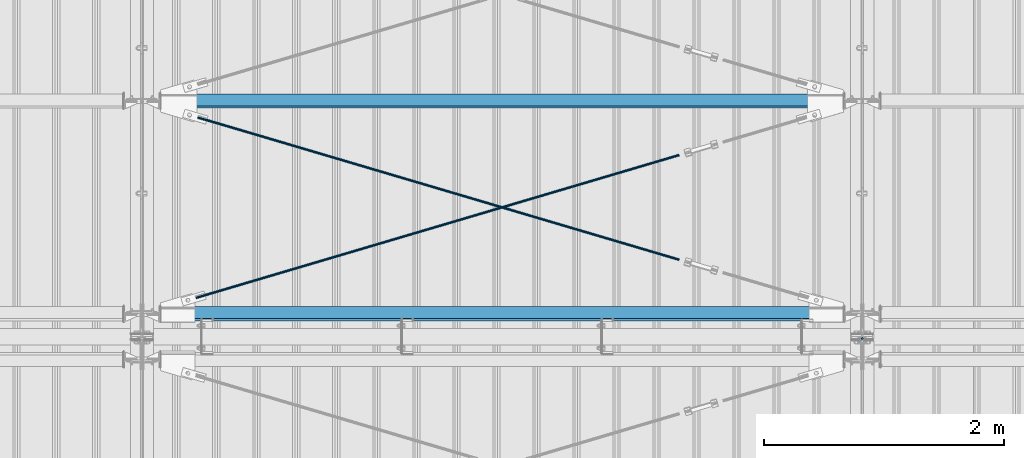
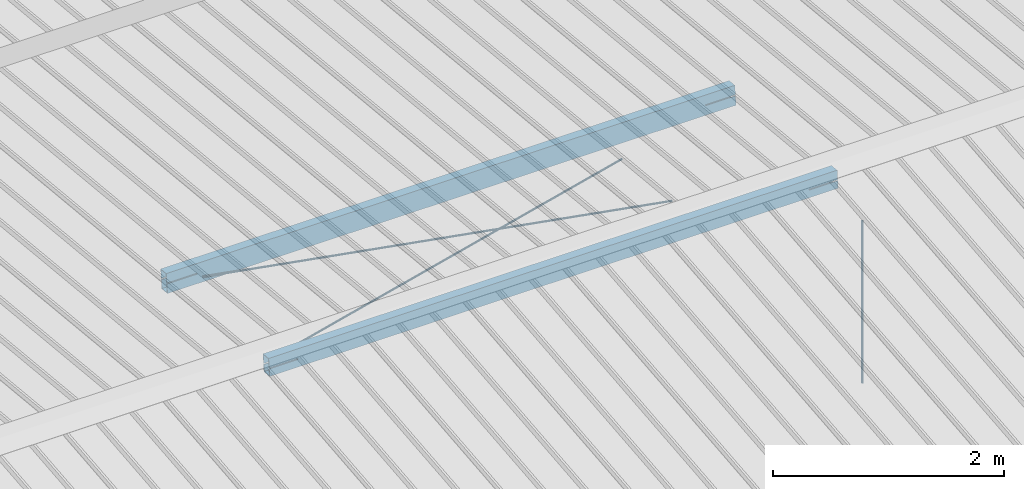
# One storey, part 281 of 709: 5 beams, 6 openings, 5 elements without a shape of their own.
"""IFC4 building model written with IfcOpenShell, lengths in millimetres."""

from ifc_helpers import new_model, si_unit, direction, frame, origin_with_axes, place, context, subcontext, project, spatial, line, indexed_curve, outline, extrude, polygons, material, element, aggregate, save


model = new_model("IFC4")

# Units and contexts
model_context = context("Model", 3, precision=0.2, world=origin_with_axes(), true_north=direction((0.0, 1.0)))
body_context = subcontext(model_context, "Body", "Model", "MODEL_VIEW")
reference_context = subcontext(model_context, "Reference", "Model", "MODEL_VIEW")
ifc_project = project(units=[si_unit("LENGTHUNIT", "METRE", prefix="MILLI"), si_unit("AREAUNIT", "SQUARE_METRE"), si_unit("VOLUMEUNIT", "CUBIC_METRE"), si_unit("MASSUNIT", "GRAM", prefix="KILO"), si_unit("TIMEUNIT", "SECOND"), si_unit("PLANEANGLEUNIT", "RADIAN"), si_unit("SOLIDANGLEUNIT", "STERADIAN"), si_unit("THERMODYNAMICTEMPERATUREUNIT", "DEGREE_CELSIUS"), si_unit("LUMINOUSINTENSITYUNIT", "LUMEN")], contexts=[model_context])

# Site, building, storey
site_placement = place(None, origin_with_axes())
site = spatial("IfcSite", under=ifc_project, at=site_placement, CompositionType="ELEMENT")
building_placement = place(site_placement, origin_with_axes())
building = spatial("IfcBuilding", under=site, at=building_placement, Name="Undefined", CompositionType="ELEMENT")
storey_placement = place(building_placement, origin_with_axes())
storey = spatial("IfcBuildingStorey", under=building, at=storey_placement, Name="Undefined", CompositionType="ELEMENT", Elevation=0.0)

# Assembly, beam
assembly_1_placement = place(storey_placement, frame((46000.0, 10985.0, 8155.10002), z_axis=(0.0, -1.0, 0.0), x_axis=(0.0, 0.0, -1.0)))
assembly_1 = element("IfcElementAssembly", 1, at=assembly_1_placement, inside=storey)
ifc_material_1 = material(Name="C355-5", Category="STEEL")
beam_1_placement = place(assembly_1_placement, origin_with_axes())
beam_1 = element("IfcBeam", 2, at=beam_1_placement, material=ifc_material_1, ObjectType="437", context=body_context, shape_type="Tessellation", body=[
    polygons([(326.36285, 0.0, 10.0), (326.36285, -2.58819, 9.65926), (2045.1, -2.58819, 9.65926), (2045.1, 0.0, 10.0), (326.36285, -5.0, 8.66025), (2045.1, -5.0, 8.66025), (326.36285, -7.07107, 7.07107), (2045.1, -7.07107, 7.07107), (326.36285, -8.66025, 5.0), (2045.1, -8.66025, 5.0), (326.36285, -9.65926, 2.58819), (2045.1, -9.65926, 2.58819), (326.36285, -10.0, 0.0), (2045.1, -10.0, 0.0), (326.36285, -9.65926, -2.58819), (2045.1, -9.65926, -2.58819), (326.36285, -8.66025, -5.0), (2045.1, -8.66025, -5.0), (326.36285, -7.07107, -7.07107), (2045.1, -7.07107, -7.07107), (326.36285, -5.0, -8.66025), (2045.1, -5.0, -8.66025), (326.36285, -2.58819, -9.65926), (2045.1, -2.58819, -9.65926), (326.36285, 0.0, -10.0), (2045.1, 0.0, -10.0), (326.36285, 2.58819, -9.65926), (2045.1, 2.58819, -9.65926), (326.36285, 5.0, -8.66025), (2045.1, 5.0, -8.66025), (326.36285, 7.07107, -7.07107), (2045.1, 7.07107, -7.07107), (326.36285, 8.66025, -5.0), (2045.1, 8.66025, -5.0), (326.36285, 9.65926, -2.58819), (2045.1, 9.65926, -2.58819), (326.36285, 10.0, 0.0), (2045.1, 10.0, 0.0), (326.36285, 9.65926, 2.58819), (2045.1, 9.65926, 2.58819), (326.36285, 8.66025, 5.0), (2045.1, 8.66025, 5.0), (326.36285, 7.07107, 7.07107), (2045.1, 7.07107, 7.07107), (326.36285, 5.0, 8.66025), (2045.1, 5.0, 8.66025), (326.36285, 2.58819, 9.65926), (2045.1, 2.58819, 9.65926)], [[[1, 2, 3, 4]], [[2, 5, 6, 3]], [[5, 7, 8, 6]], [[7, 9, 10, 8]], [[9, 11, 12, 10]], [[11, 13, 14, 12]], [[13, 15, 16, 14]], [[15, 17, 18, 16]], [[17, 19, 20, 18]], [[19, 21, 22, 20]], [[21, 23, 24, 22]], [[23, 25, 26, 24]], [[25, 27, 28, 26]], [[27, 29, 30, 28]], [[29, 31, 32, 30]], [[31, 33, 34, 32]], [[33, 35, 36, 34]], [[35, 37, 38, 36]], [[37, 39, 40, 38]], [[39, 41, 42, 40]], [[41, 43, 44, 42]], [[43, 45, 46, 44]], [[45, 47, 48, 46]], [[47, 1, 4, 48]], [[6, 8, 10, 12, 14, 16, 18, 20, 22, 24, 26, 28, 30, 32, 34, 36, 38, 40, 42, 44, 46, 48, 4, 3]], [[47, 45, 43, 41, 39, 37, 35, 33, 31, 29, 27, 25, 23, 21, 19, 17, 15, 13, 11, 9, 7, 5, 2, 1]]], closed=True),
])
aggregate(assembly_1, [beam_1])

# Assembly, beam, voiding feature
assembly_2_placement = place(storey_placement, frame((40000.0, 11190.84566, 8217.41945), z_axis=(0.2847296511, -0.9538504697, 0.095385047), x_axis=(0.9586078582, 0.2833165921, -0.028331659)))
assembly_2 = element("IfcElementAssembly", 3, at=assembly_2_placement, inside=storey)
beam_2_placement = place(assembly_2_placement, origin_with_axes())
beam_2 = element("IfcBeam", 4, at=beam_2_placement, material=ifc_material_1, ObjectType="573", context=body_context, shape_type="Tessellation", body=[
    polygons([(4849.07659, 7.36121, 4.25), (4849.07659, 6.01041, 6.01041), (4849.07659, 4.25, 7.36122), (4849.07659, 2.19996, 8.21037), (4849.07659, 0.0, 8.5), (4849.07659, -2.19996, 8.21037), (4849.07659, -4.25, 7.36122), (4849.07659, -6.01041, 6.01041), (4849.07659, -7.36122, 4.25), (4849.07659, -8.21037, 2.19996), (4849.07659, -8.5, 0.0), (4849.07659, -8.21037, -2.19996), (4849.07659, -7.36122, -4.25), (4849.07659, -6.01041, -6.01041), (4849.07659, -4.25, -7.36122), (4849.07659, -2.19996, -8.21037), (4849.07659, 0.0, -8.5), (4849.07659, 2.19996, -8.21037), (4849.07659, 4.25, -7.36122), (4849.07659, 6.01041, -6.01041), (4849.07659, 7.36121, -4.25), (4849.07659, 8.21037, -2.19996), (4849.07659, 8.5, 0.0), (4849.07659, 8.21037, 2.19996), (4669.07659, 8.21037, 2.19996), (4669.07659, 7.36121, 4.25), (4669.07659, 6.01041, 6.01041), (4669.07659, 4.25, 7.36122), (4669.07659, 2.19996, 8.21037), (4669.07659, 0.0, 8.5), (4669.07659, -2.19996, 8.21037), (4669.07659, -4.25, 7.36122), (4669.07659, -6.01041, 6.01041), (4669.07659, -7.36122, 4.25), (4669.07659, -8.21037, 2.19996), (4669.07659, -8.5, 0.0), (4669.07659, -8.21037, -2.19996), (4669.07659, -7.36122, -4.25), (4669.07659, -6.01041, -6.01041), (4669.07659, -4.25, -7.36122), (4669.07659, -2.19996, -8.21037), (4669.07659, 0.0, -8.5), (4669.07659, 2.19996, -8.21037), (4669.07659, 4.25, -7.36122), (4669.07659, 6.01041, -6.01041), (4669.07659, 7.36121, -4.25), (4669.07659, 8.21037, -2.19996), (4669.07659, 8.5, 0.0), (4669.07659, 10.0, 0.0), (4669.07659, 9.65926, 2.58819), (4669.07659, 8.66025, 5.0), (4669.07659, 7.07107, 7.07107), (4669.07659, 5.0, 8.66025), (4669.07659, 2.58819, 9.65926), (4669.07659, 0.0, 10.0), (4669.07659, -2.58819, 9.65926), (4669.07659, -5.0, 8.66025), (4669.07659, -7.07107, 7.07107), (4669.07659, -8.66025, 5.0), (4669.07659, -9.65926, 2.58819), (4669.07659, -10.0, 0.0), (4669.07659, -9.65926, -2.58819), (4669.07659, -8.66025, -5.0), (4669.07659, -7.07107, -7.07107), (4669.07659, -5.0, -8.66025), (4669.07659, -2.58819, -9.65926), (4669.07659, 0.0, -10.0), (4669.07659, 2.58819, -9.65926), (4669.07659, 5.0, -8.66025), (4669.07659, 7.07107, -7.07107), (4669.07659, 8.66025, -5.0), (4669.07659, 9.65926, -2.58819), (468.68279, 2.58819, 9.65926), (468.68279, 5.0, 8.66025), (468.68279, 7.07107, 7.07107), (468.68279, 8.66025, 5.0), (468.68279, 9.65926, 2.58819), (468.68279, 10.0, 0.0), (468.68279, 9.65926, -2.58819), (468.68279, 8.66025, -5.0), (468.68279, 7.07107, -7.07107), (468.68279, 5.0, -8.66025), (468.68279, 2.58819, -9.65926), (468.68279, 0.0, -10.0), (468.68279, -2.58819, -9.65926), (468.68279, -5.0, -8.66025), (468.68279, -7.07107, -7.07107), (468.68279, -8.66025, -5.0), (468.68279, -9.65926, -2.58819), (468.68279, -10.0, 0.0), (468.68279, -9.65926, 2.58819), (468.68279, -8.66025, 5.0), (468.68279, -7.07107, 7.07107), (468.68279, -5.0, 8.66025), (468.68279, -2.58819, 9.65926), (468.68279, 0.0, 10.0)], [[[1, 2, 3, 4, 5, 6, 7, 8, 9, 10, 11, 12, 13, 14, 15, 16, 17, 18, 19, 20, 21, 22, 23, 24]], [[24, 25, 26, 1]], [[1, 26, 27, 2]], [[2, 27, 28, 3]], [[3, 28, 29, 4]], [[4, 29, 30, 5]], [[5, 30, 31, 6]], [[6, 31, 32, 7]], [[7, 32, 33, 8]], [[8, 33, 34, 9]], [[9, 34, 35, 10]], [[10, 35, 36, 11]], [[11, 36, 37, 12]], [[12, 37, 38, 13]], [[13, 38, 39, 14]], [[14, 39, 40, 15]], [[15, 40, 41, 16]], [[16, 41, 42, 17]], [[17, 42, 43, 18]], [[18, 43, 44, 19]], [[19, 44, 45, 20]], [[20, 45, 46, 21]], [[21, 46, 47, 22]], [[22, 47, 48, 23]], [[23, 48, 25, 24]], [[49, 50, 51, 52, 53, 54, 55, 56, 57, 58, 59, 60, 61, 62, 63, 64, 65, 66, 67, 68, 69, 70, 71, 72], [47, 46, 45, 44, 43, 42, 41, 40, 39, 38, 37, 36, 35, 34, 33, 32, 31, 30, 29, 28, 27, 26, 25, 48]], [[73, 74, 75, 76, 77, 78, 79, 80, 81, 82, 83, 84, 85, 86, 87, 88, 89, 90, 91, 92, 93, 94, 95, 96]], [[79, 78, 49, 72]], [[80, 79, 72, 71]], [[81, 80, 71, 70]], [[82, 81, 70, 69]], [[83, 82, 69, 68]], [[84, 83, 68, 67]], [[85, 84, 67, 66]], [[86, 85, 66, 65]], [[87, 86, 65, 64]], [[88, 87, 64, 63]], [[89, 88, 63, 62]], [[90, 89, 62, 61]], [[91, 90, 61, 60]], [[92, 91, 60, 59]], [[93, 92, 59, 58]], [[94, 93, 58, 57]], [[95, 94, 57, 56]], [[96, 95, 56, 55]], [[73, 96, 55, 54]], [[74, 73, 54, 53]], [[75, 74, 53, 52]], [[76, 75, 52, 51]], [[77, 76, 51, 50]], [[78, 77, 50, 49]]], closed=True),
])
voiding_feature_1_placement = place(beam_2_placement, frame((4849.07659, 0.0, 0.0), z_axis=(0.0, 1.0, 0.0), x_axis=(-1.0, 0.0, 0.0)))
element("IfcVoidingFeature", 5, at=voiding_feature_1_placement, cuts=beam_2, PredefinedType="HOLE", context=reference_context, identifier="Reference", shape_type="SolidModel", body=[
    extrude(outline(indexed_curve([(10.5, 0.0), (10.14222, 2.7176), (9.09327, 5.25), (7.42462, 7.42462), (5.25, 9.09327), (2.7176, 10.14222), (0.0, 10.5), (-2.7176, 10.14222), (-5.25, 9.09327), (-7.42462, 7.42462), (-9.09327, 5.25), (-10.14222, 2.7176), (-10.5, 0.0), (-10.14222, -2.7176), (-9.09327, -5.25), (-7.42462, -7.42462), (-5.25, -9.09327), (-2.7176, -10.14222), (0.0, -10.5), (2.7176, -10.14222), (5.25, -9.09327), (7.42462, -7.42462), (9.09327, -5.25), (10.14222, -2.7176)], segments=[line(1, 2, 3, 4, 5, 6, 7, 8, 9, 10, 11, 12, 13, 14, 15, 16, 17, 18, 19, 20, 21, 22, 23, 24, 1)])), frame((0.0, 0.0, 0.0), z_axis=(-1.0, 0.0, 0.0), x_axis=(0.0, 0.0, 1.0)), (0.0, 0.0, -1.0), 180.0),
])
aggregate(assembly_2, [beam_2])

assembly_3_placement = place(storey_placement, frame((40000.0, 12964.14591, 8040.08943), z_axis=(-0.2847296511, -0.9538504697, 0.095385047), x_axis=(0.9586078582, -0.2833165921, 0.028331659)))
assembly_3 = element("IfcElementAssembly", 6, at=assembly_3_placement, inside=storey)
beam_3_placement = place(assembly_3_placement, origin_with_axes())
beam_3 = element("IfcBeam", 7, at=beam_3_placement, material=ifc_material_1, ObjectType="572", context=body_context, shape_type="Tessellation", body=[
    polygons([(4849.07659, 7.36122, 4.25), (4849.07659, 6.01041, 6.01041), (4849.07659, 4.25, 7.36122), (4849.07659, 2.19996, 8.21037), (4849.07659, 0.0, 8.5), (4849.07659, -2.19996, 8.21037), (4849.07659, -4.25, 7.36122), (4849.07659, -6.01041, 6.01041), (4849.07659, -7.36121, 4.25), (4849.07659, -8.21037, 2.19996), (4849.07659, -8.5, 0.0), (4849.07659, -8.21037, -2.19996), (4849.07659, -7.36121, -4.25), (4849.07659, -6.01041, -6.01041), (4849.07659, -4.25, -7.36122), (4849.07659, -2.19996, -8.21037), (4849.07659, 0.0, -8.5), (4849.07659, 2.19996, -8.21037), (4849.07659, 4.25, -7.36122), (4849.07659, 6.01041, -6.01041), (4849.07659, 7.36122, -4.25), (4849.07659, 8.21037, -2.19996), (4849.07659, 8.5, 0.0), (4849.07659, 8.21037, 2.19996), (4669.07659, 8.21037, 2.19996), (4669.07659, 7.36122, 4.25), (4669.07659, 6.01041, 6.01041), (4669.07659, 4.25, 7.36122), (4669.07659, 2.19996, 8.21037), (4669.07659, 0.0, 8.5), (4669.07659, -2.19996, 8.21037), (4669.07659, -4.25, 7.36122), (4669.07659, -6.01041, 6.01041), (4669.07659, -7.36121, 4.25), (4669.07659, -8.21037, 2.19996), (4669.07659, -8.5, 0.0), (4669.07659, -8.21037, -2.19996), (4669.07659, -7.36121, -4.25), (4669.07659, -6.01041, -6.01041), (4669.07659, -4.25, -7.36122), (4669.07659, -2.19996, -8.21037), (4669.07659, 0.0, -8.5), (4669.07659, 2.19996, -8.21037), (4669.07659, 4.25, -7.36122), (4669.07659, 6.01041, -6.01041), (4669.07659, 7.36122, -4.25), (4669.07659, 8.21037, -2.19996), (4669.07659, 8.5, 0.0), (4669.07659, 10.0, 0.0), (4669.07659, 9.65926, 2.58819), (4669.07659, 8.66025, 5.0), (4669.07659, 7.07107, 7.07107), (4669.07659, 5.0, 8.66025), (4669.07659, 2.58819, 9.65926), (4669.07659, 0.0, 10.0), (4669.07659, -2.58819, 9.65926), (4669.07659, -5.0, 8.66025), (4669.07659, -7.07107, 7.07107), (4669.07659, -8.66025, 5.0), (4669.07659, -9.65926, 2.58819), (4669.07659, -10.0, 0.0), (4669.07659, -9.65926, -2.58819), (4669.07659, -8.66025, -5.0), (4669.07659, -7.07107, -7.07107), (4669.07659, -5.0, -8.66025), (4669.07659, -2.58819, -9.65926), (4669.07659, 0.0, -10.0), (4669.07659, 2.58819, -9.65926), (4669.07659, 5.0, -8.66025), (4669.07659, 7.07107, -7.07107), (4669.07659, 8.66025, -5.0), (4669.07659, 9.65926, -2.58819), (483.68279, 2.58819, 9.65926), (483.68279, 5.0, 8.66025), (483.68279, 7.07107, 7.07107), (483.68279, 8.66025, 5.0), (483.68279, 9.65926, 2.58819), (483.68279, 10.0, 0.0), (483.68279, 9.65926, -2.58819), (483.68279, 8.66025, -5.0), (483.68279, 7.07107, -7.07107), (483.68279, 5.0, -8.66025), (483.68279, 2.58819, -9.65926), (483.68279, 0.0, -10.0), (483.68279, -2.58819, -9.65926), (483.68279, -5.0, -8.66025), (483.68279, -7.07107, -7.07107), (483.68279, -8.66025, -5.0), (483.68279, -9.65926, -2.58819), (483.68279, -10.0, 0.0), (483.68279, -9.65926, 2.58819), (483.68279, -8.66025, 5.0), (483.68279, -7.07107, 7.07107), (483.68279, -5.0, 8.66025), (483.68279, -2.58819, 9.65926), (483.68279, 0.0, 10.0)], [[[1, 2, 3, 4, 5, 6, 7, 8, 9, 10, 11, 12, 13, 14, 15, 16, 17, 18, 19, 20, 21, 22, 23, 24]], [[24, 25, 26, 1]], [[1, 26, 27, 2]], [[2, 27, 28, 3]], [[3, 28, 29, 4]], [[4, 29, 30, 5]], [[5, 30, 31, 6]], [[6, 31, 32, 7]], [[7, 32, 33, 8]], [[8, 33, 34, 9]], [[9, 34, 35, 10]], [[10, 35, 36, 11]], [[11, 36, 37, 12]], [[12, 37, 38, 13]], [[13, 38, 39, 14]], [[14, 39, 40, 15]], [[15, 40, 41, 16]], [[16, 41, 42, 17]], [[17, 42, 43, 18]], [[18, 43, 44, 19]], [[19, 44, 45, 20]], [[20, 45, 46, 21]], [[21, 46, 47, 22]], [[22, 47, 48, 23]], [[23, 48, 25, 24]], [[49, 50, 51, 52, 53, 54, 55, 56, 57, 58, 59, 60, 61, 62, 63, 64, 65, 66, 67, 68, 69, 70, 71, 72], [47, 46, 45, 44, 43, 42, 41, 40, 39, 38, 37, 36, 35, 34, 33, 32, 31, 30, 29, 28, 27, 26, 25, 48]], [[73, 74, 75, 76, 77, 78, 79, 80, 81, 82, 83, 84, 85, 86, 87, 88, 89, 90, 91, 92, 93, 94, 95, 96]], [[79, 78, 49, 72]], [[80, 79, 72, 71]], [[81, 80, 71, 70]], [[82, 81, 70, 69]], [[83, 82, 69, 68]], [[84, 83, 68, 67]], [[85, 84, 67, 66]], [[86, 85, 66, 65]], [[87, 86, 65, 64]], [[88, 87, 64, 63]], [[89, 88, 63, 62]], [[90, 89, 62, 61]], [[91, 90, 61, 60]], [[92, 91, 60, 59]], [[93, 92, 59, 58]], [[94, 93, 58, 57]], [[95, 94, 57, 56]], [[96, 95, 56, 55]], [[73, 96, 55, 54]], [[74, 73, 54, 53]], [[75, 74, 53, 52]], [[76, 75, 52, 51]], [[77, 76, 51, 50]], [[78, 77, 50, 49]]], closed=True),
])
voiding_feature_2_placement = place(beam_3_placement, frame((4849.07659, 0.0, 0.0), z_axis=(0.0, 1.0, 0.0), x_axis=(-1.0, 0.0, 0.0)))
element("IfcVoidingFeature", 8, at=voiding_feature_2_placement, cuts=beam_3, PredefinedType="HOLE", context=reference_context, identifier="Reference", shape_type="SolidModel", body=[
    extrude(outline(indexed_curve([(10.5, 0.0), (10.14222, 2.7176), (9.09327, 5.25), (7.42462, 7.42462), (5.25, 9.09327), (2.7176, 10.14222), (0.0, 10.5), (-2.7176, 10.14222), (-5.25, 9.09327), (-7.42462, 7.42462), (-9.09327, 5.25), (-10.14222, 2.7176), (-10.5, 0.0), (-10.14222, -2.7176), (-9.09327, -5.25), (-7.42462, -7.42462), (-5.25, -9.09327), (-2.7176, -10.14222), (0.0, -10.5), (2.7176, -10.14222), (5.25, -9.09327), (7.42462, -7.42462), (9.09327, -5.25), (10.14222, -2.7176)], segments=[line(1, 2, 3, 4, 5, 6, 7, 8, 9, 10, 11, 12, 13, 14, 15, 16, 17, 18, 19, 20, 21, 22, 23, 24, 1)])), frame((0.0, 0.0, 0.0), z_axis=(-1.0, 0.0, 0.0), x_axis=(0.0, 0.0, 1.0)), (0.0, 0.0, -1.0), 180.0),
])
aggregate(assembly_3, [beam_3])

# Assembly, beam, voiding features
assembly_4_placement = place(storey_placement, frame((46000.0, 11191.04467, 8219.40952), z_axis=(0.0, -0.9950371902, 0.099503719), x_axis=(-1.0, 0.0, 0.0)))
assembly_4 = element("IfcElementAssembly", 9, at=assembly_4_placement, inside=storey)
ifc_material_2 = material(Name="C355", Category="STEEL")
beam_4_placement = place(assembly_4_placement, origin_with_axes())
beam_4 = element("IfcBeam", 10, at=beam_4_placement, material=ifc_material_2, ObjectType="567", context=body_context, shape_type="Tessellation", body=[
    polygons([(442.92369, 5.0, 50.0), (442.92369, 5.0, 46.0), (155.0, 5.0, 46.0), (155.0, 5.0, 50.0), (442.92369, 15.0, 50.0), (442.92369, 15.0, 46.0), (155.0, 15.0, 50.0), (155.0, 15.0, 46.0), (442.92369, 5.0, -46.0), (442.92369, 5.0, -50.0), (155.0, 5.0, -50.0), (155.0, 5.0, -46.0), (442.92369, 15.0, -46.0), (442.92369, 15.0, -50.0), (155.0, 15.0, -46.0), (155.0, 15.0, -50.0), (155.0, 86.0, 46.0), (155.0, 86.0, -46.0), (5845.0, 86.0, -46.0), (5845.0, 86.0, 46.0), (155.0, 90.0, -50.0), (5845.0, 90.0, -50.0), (5845.0, 15.0, -50.0), (5557.07631, 15.0, -50.0), (5557.07631, 5.0, -50.0), (5845.0, 5.0, -50.0), (5845.0, -90.0, -50.0), (155.0, -90.0, -50.0), (5845.0, 15.0, -46.0), (5557.07631, 15.0, -46.0), (5557.07631, 5.0, -46.0), (5845.0, 5.0, -46.0), (155.0, -86.0, -46.0), (155.0, -86.0, 46.0), (5845.0, -86.0, 46.0), (5845.0, -86.0, -46.0), (5557.07631, 5.0, 50.0), (5557.07631, 5.0, 46.0), (5557.07631, 15.0, 46.0), (5557.07631, 15.0, 50.0), (5845.0, 5.0, 50.0), (5845.0, 5.0, 46.0), (5845.0, -90.0, 50.0), (155.0, -90.0, 50.0), (5845.0, 15.0, 46.0), (5845.0, 15.0, 50.0), (5845.0, 90.0, 50.0), (155.0, 90.0, 50.0)], [[[1, 2, 3, 4]], [[5, 6, 2, 1]], [[7, 8, 6, 5]], [[9, 10, 11, 12]], [[13, 14, 10, 9]], [[15, 16, 14, 13]], [[17, 18, 19, 20]], [[21, 22, 23, 24, 25, 26, 27, 28, 11, 10, 14, 16]], [[29, 30, 24, 23]], [[31, 25, 24, 30]], [[32, 26, 25, 31]], [[33, 34, 35, 36]], [[37, 38, 39, 40]], [[41, 42, 38, 37]], [[43, 27, 26, 32, 36, 35, 42, 41]], [[44, 28, 27, 43]], [[34, 33, 12, 11, 28, 44, 4, 3]], [[17, 20, 45, 39, 38, 42, 35, 34, 3, 2, 6, 8]], [[46, 40, 39, 45]], [[20, 19, 29, 23, 22, 47, 46, 45]], [[21, 48, 47, 22]], [[4, 44, 43, 41, 37, 40, 46, 47, 48, 7, 5, 1]], [[48, 21, 16, 15, 18, 17, 8, 7]], [[12, 33, 36, 32, 31, 30, 29, 19, 18, 15, 13, 9]]], closed=True),
])
voiding_feature_3_placement = place(beam_4_placement, frame((5845.0, 10.0, 70.0), z_axis=(0.0, -1.0, 0.0), x_axis=(-1.0, 0.0, 0.0)))
element("IfcVoidingFeature", 11, at=voiding_feature_3_placement, cuts=beam_4, PredefinedType="HOLE", context=reference_context, identifier="Reference", shape_type="SolidModel", body=[
    extrude(outline(indexed_curve([(0.0, 0.0), (287.92369, 0.0), (287.92369, 154.61594), (262.29802, 240.89065), (0.0, 162.98181)], segments=[line(1, 2, 3, 4, 5, 1)])), frame((0.0, 0.0, 5.0), z_axis=(0.0, 0.0, 1.0), x_axis=(1.0, 0.0, 0.0)), (0.0, 0.0, -1.0), 10.0),
])
voiding_feature_4_placement = place(beam_4_placement, frame((442.92369, 10.0, 70.0), z_axis=(0.0, -1.0, 0.0), x_axis=(-1.0, 0.0, 0.0)))
element("IfcVoidingFeature", 12, at=voiding_feature_4_placement, cuts=beam_4, PredefinedType="HOLE", context=reference_context, identifier="Reference", shape_type="SolidModel", body=[
    extrude(outline(indexed_curve([(0.0, 0.0), (287.92369, 0.0), (287.92369, 162.98181), (25.62567, 240.89065), (0.0, 154.61594)], segments=[line(1, 2, 3, 4, 5, 1)])), frame((0.0, 0.0, 5.0), z_axis=(0.0, 0.0, 1.0), x_axis=(1.0, 0.0, 0.0)), (0.0, 0.0, -1.0), 10.0),
])
aggregate(assembly_4, [beam_4])

assembly_5_placement = place(storey_placement, frame((46000.0, 12963.34988, 8032.12913), z_axis=(0.0, -0.9950371902, 0.099503719), x_axis=(-1.0, 0.0, 0.0)))
assembly_5 = element("IfcElementAssembly", 13, at=assembly_5_placement, inside=storey)
beam_5_placement = place(assembly_5_placement, origin_with_axes())
beam_5 = element("IfcBeam", 14, at=beam_5_placement, material=ifc_material_2, ObjectType="566", context=body_context, shape_type="Tessellation", body=[
    polygons([(457.3028, -5.0, 50.0), (457.3028, -5.0, 46.0), (155.0, -5.0, 46.0), (155.0, -5.0, 50.0), (457.3028, 5.0, 50.0), (457.3028, 5.0, 46.0), (155.0, 5.0, 50.0), (155.0, 5.0, 46.0), (457.3028, -5.0, -46.0), (457.3028, -5.0, -50.0), (155.0, -5.0, -50.0), (155.0, -5.0, -46.0), (457.3028, 5.0, -46.0), (457.3028, 5.0, -50.0), (155.0, 5.0, -46.0), (155.0, 5.0, -50.0), (155.0, 96.0, 46.0), (155.0, 96.0, -46.0), (5845.0, 96.0, -46.0), (5845.0, 96.0, 46.0), (155.0, 100.0, -50.0), (5845.0, 100.0, -50.0), (5845.0, 5.0, -50.0), (5542.6972, 5.0, -50.0), (5542.6972, -5.0, -50.0), (5845.0, -5.0, -50.0), (5845.0, -100.0, -50.0), (155.0, -100.0, -50.0), (5845.00055, 5.0, -46.0), (5542.6972, 5.0, -46.0), (5542.6972, -5.0, -46.0), (5845.0, -5.0, -46.0), (155.0, -96.0, -46.0), (155.0, -96.0, 46.0), (5845.0, -96.0, 46.0), (5845.0, -96.0, -46.0), (5542.6972, -5.0, 50.0), (5542.6972, -5.0, 46.0), (5542.6972, 5.0, 46.0), (5542.6972, 5.0, 50.0), (5845.0, -5.0, 50.0), (5845.0, -5.0, 46.0), (5845.0, -100.0, 50.0), (155.0, -100.0, 50.0), (5845.0, 5.0, 46.0), (5845.00055, 5.0, 50.0), (5845.0, 100.0, 50.0), (155.0, 100.0, 50.0)], [[[1, 2, 3, 4]], [[5, 6, 2, 1]], [[7, 8, 6, 5]], [[9, 10, 11, 12]], [[13, 14, 10, 9]], [[15, 16, 14, 13]], [[17, 18, 19, 20]], [[21, 22, 23, 24, 25, 26, 27, 28, 11, 10, 14, 16]], [[29, 30, 24, 23]], [[31, 25, 24, 30]], [[32, 26, 25, 31]], [[33, 34, 35, 36]], [[37, 38, 39, 40]], [[41, 42, 38, 37]], [[43, 27, 26, 32, 36, 35, 42, 41]], [[44, 28, 27, 43]], [[34, 33, 12, 11, 28, 44, 4, 3]], [[17, 20, 45, 39, 38, 42, 35, 34, 3, 2, 6, 8]], [[46, 40, 39, 45]], [[20, 19, 29, 23, 22, 47, 46, 45]], [[21, 48, 47, 22]], [[4, 44, 43, 41, 37, 40, 46, 47, 48, 7, 5, 1]], [[48, 21, 16, 15, 18, 17, 8, 7]], [[12, 33, 36, 32, 31, 30, 29, 19, 18, 15, 13, 9]]], closed=True),
])
voiding_feature_5_placement = place(beam_5_placement, frame((5845.00055, 0.0, -92.98165), z_axis=(0.0, -1.0, 0.0), x_axis=(0.0, 0.0, 1.0)))
element("IfcVoidingFeature", 15, at=voiding_feature_5_placement, cuts=beam_5, Name="PLATE", PredefinedType="HOLE", context=reference_context, identifier="Reference", shape_type="SolidModel", body=[
    extrude(outline(indexed_curve([(0.0, 0.0), (185.9633, 0.0), (268.14324, 276.67769), (181.86854, 302.30336), (4.09476, 302.30336), (-82.17995, 276.67769)], segments=[line(1, 2, 3, 4, 5, 6, 1)])), frame((0.0, 0.0, 5.0), z_axis=(0.0, 0.0, 1.0), x_axis=(1.0, 0.0, 0.0)), (0.0, 0.0, -1.0), 10.0),
])
voiding_feature_6_placement = place(beam_5_placement, frame((154.99945, 0.0, 92.98165), z_axis=(0.0, -1.0, 0.0), x_axis=(0.0, 0.0, -1.0)))
element("IfcVoidingFeature", 16, at=voiding_feature_6_placement, cuts=beam_5, Name="PLATE", PredefinedType="HOLE", context=reference_context, identifier="Reference", shape_type="SolidModel", body=[
    extrude(outline(indexed_curve([(0.0, 0.0), (185.9633, 0.0), (268.14324, 276.67769), (181.86854, 302.30336), (4.09476, 302.30336), (-82.17995, 276.67769)], segments=[line(1, 2, 3, 4, 5, 6, 1)])), frame((0.0, 0.0, 5.0), z_axis=(0.0, 0.0, 1.0), x_axis=(1.0, 0.0, 0.0)), (0.0, 0.0, -1.0), 10.0),
])
aggregate(assembly_5, [beam_5])

save(model, "model.ifc")
